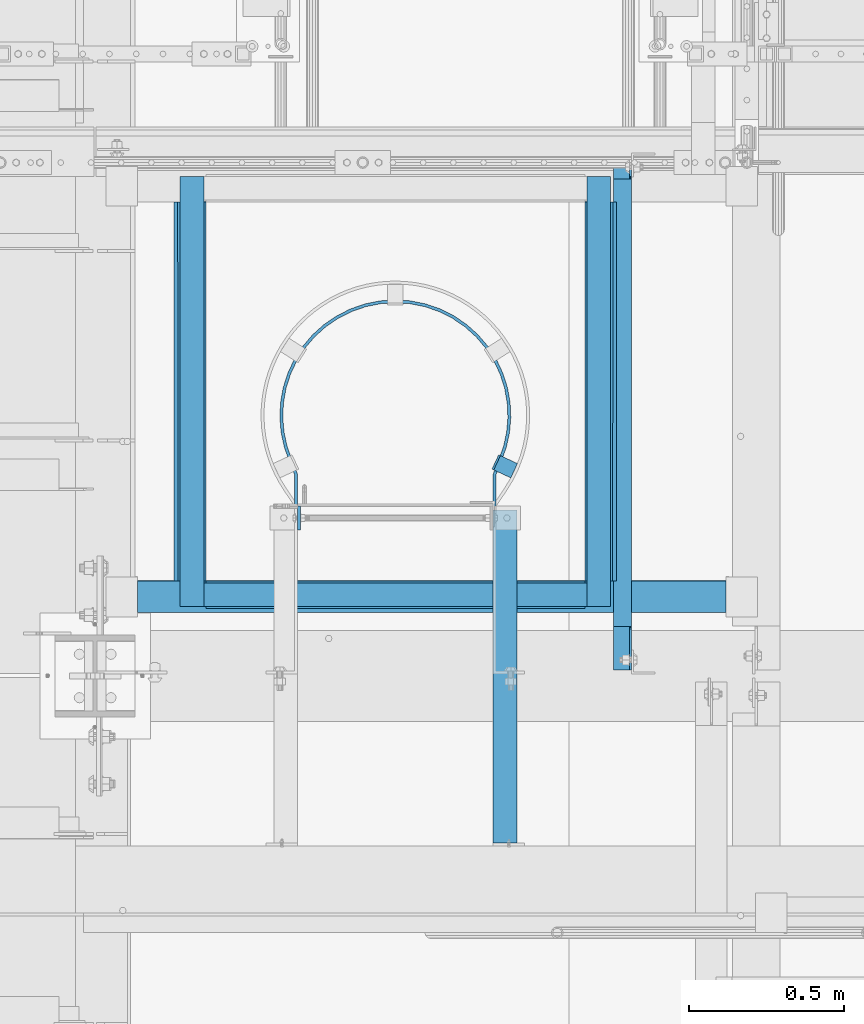
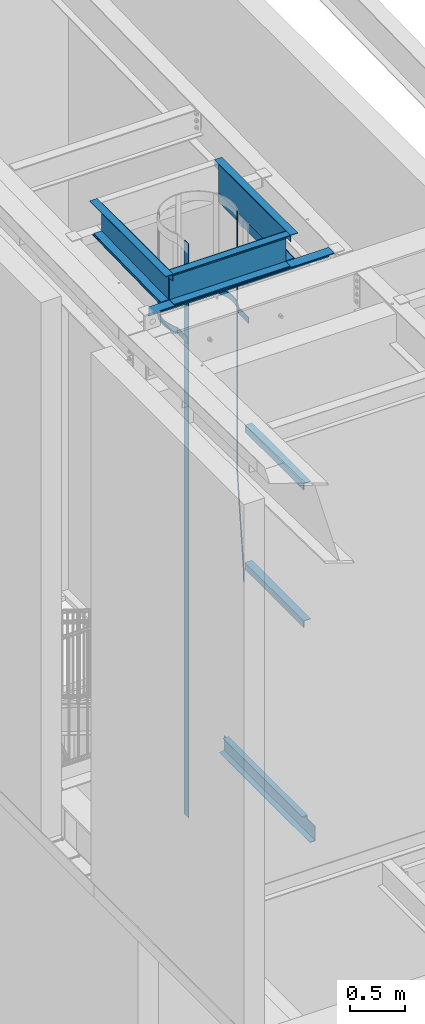
# One storey, part 1079 of 1763: 15 beams, 4 elements without a shape of their own.
"""IFC2X3 building model written with IfcOpenShell, lengths in millimetres."""

from ifc_helpers import new_model, si_unit, frame, origin_with_axes, place, context, subcontext, project, spatial, faceted_brep, material, type_object, element, aggregate, save


model = new_model("IFC2X3")

# Units and contexts
model_context = context("Model", 3, precision=1e-05, world=origin_with_axes())
body_context = subcontext(model_context, "Body", "Model", "MODEL_VIEW")
ifc_project = project(units=[si_unit("LENGTHUNIT", "METRE", prefix="MILLI"), si_unit("AREAUNIT", "SQUARE_METRE"), si_unit("VOLUMEUNIT", "CUBIC_METRE"), si_unit("MASSUNIT", "GRAM", prefix="KILO"), si_unit("TIMEUNIT", "SECOND"), si_unit("PLANEANGLEUNIT", "RADIAN"), si_unit("SOLIDANGLEUNIT", "STERADIAN"), si_unit("THERMODYNAMICTEMPERATUREUNIT", "DEGREE_CELSIUS"), si_unit("LUMINOUSINTENSITYUNIT", "LUMEN")], contexts=[model_context])

# Site, building, storey
site_placement = place(None, origin_with_axes())
site = spatial("IfcSite", under=ifc_project, at=site_placement, CompositionType="ELEMENT")
building_placement = place(site_placement, origin_with_axes())
building = spatial("IfcBuilding", under=site, at=building_placement, Name="Undefined", CompositionType="ELEMENT")
storey_placement = place(building_placement, origin_with_axes())
storey = spatial("IfcBuildingStorey", under=building, at=storey_placement, Name="Undefined", CompositionType="ELEMENT", Elevation=0.0)

# Assembly, beams
assembly_1_placement = place(storey_placement, origin_with_axes())
assembly_1 = element("IfcElementAssembly", 1, at=assembly_1_placement, inside=storey, Name="ANGLE", AssemblyPlace="NOTDEFINED", PredefinedType="RIGID_FRAME")
ifc_material = material(Name="STEEL/A36")
beam_type_1 = type_object("IfcBeamType", Name="L4X4X3/8", PredefinedType="NOTDEFINED")
beam_1_placement = place(assembly_1_placement, frame((-85749.8046875, 30328.926989345, 11245.4581872207), z_axis=(1.0, 0.0, 0.0), x_axis=(0.0, 0.999779834654609, 0.0209829029927513)))
beam_1 = element("IfcBeam", 2, at=beam_1_placement, type_object=beam_type_1, material=ifc_material, Name="ANGLE", ObjectType="L4X4X3/8", context=body_context, shape_type="Brep", body=[
    faceted_brep([(-3.63797880709171e-11, 50.8000000000011, -50.8000000000538), (-1.96450855582952e-10, 50.8000000000393, 50.7999999999374), (1219.28504414436, 50.8000000010161, 50.8000000000029), (1219.28504414436, 50.8000000010161, -50.8000000000029), (0.0, 41.2749999999996, 50.7999999999993), (1219.28504414434, 41.2750000010237, 50.8000000000029), (0.0, 41.2749999999996, -41.2750000000015), (1219.28504414434, 41.2750000010237, -41.2749999999942), (0.0, -50.7999999999993, -41.2750000000015), (1219.28504414426, -50.7999999989152, -41.2749999999942), (2.11002770811319e-10, -50.8000000000357, -50.799999999952), (1219.28504414426, -50.7999999989152, -50.8000000000029)], [[[0, 1, 2, 3]], [[1, 4, 5, 2]], [[4, 6, 7, 5]], [[6, 8, 9, 7]], [[8, 10, 11, 9]], [[10, 0, 3, 11]], [[5, 7, 9, 11, 3, 2]], [[10, 8, 6, 4, 1, 0]]]),
])
beam_2_placement = place(assembly_1_placement, frame((-87070.6046875, 31547.9435891844, 11271.0423265732), z_axis=(-1.0, 0.0, 0.0), x_axis=(0.0, -0.999779834654609, -0.0209829029927513)))
beam_2 = element("IfcBeam", 3, at=beam_2_placement, type_object=beam_type_1, material=ifc_material, Name="ANGLE", ObjectType="L4X4X3/8", context=body_context, shape_type="Brep", body=[
    faceted_brep([(-3.63797880709171e-11, 50.8000000000011, -50.8000000000538), (-1.96450855582952e-10, 50.8000000000393, 50.7999999999374), (1219.28504414436, 50.8000000010161, 50.8000000000029), (1219.28504414436, 50.8000000010161, -50.8000000000029), (0.0, 41.2749999999996, 50.7999999999993), (1219.28504414434, 41.2750000010237, 50.8000000000029), (0.0, 41.2749999999996, -41.2750000000015), (1219.28504414434, 41.2750000010237, -41.2749999999942), (0.0, -50.7999999999993, -41.2750000000015), (1219.28504414426, -50.7999999989152, -41.2749999999942), (2.11002770811319e-10, -50.8000000000357, -50.799999999952), (1219.28504414426, -50.7999999989152, -50.8000000000029)], [[[0, 1, 2, 3]], [[1, 4, 5, 2]], [[4, 6, 7, 5]], [[6, 8, 9, 7]], [[8, 10, 11, 9]], [[10, 0, 3, 11]], [[5, 7, 9, 11, 3, 2]], [[10, 8, 6, 4, 1, 0]]]),
])
beam_3_placement = place(assembly_1_placement, frame((-87238.9122736984, 30278.1707527682, 11244.3929395204), z_axis=(0.0, -0.999779834654609, -0.0209829029927513), x_axis=(1.0, 0.0, 0.0)))
beam_3 = element("IfcBeam", 4, at=beam_3_placement, type_object=beam_type_1, material=ifc_material, Name="ANGLE", ObjectType="L4X4X3/8", context=body_context, shape_type="Brep", body=[
    faceted_brep([(-3.63797880709171e-11, 50.8000000000011, -50.8000000000538), (-1.96450855582952e-10, 50.8000000000393, 50.7999999999374), (1891.39285714286, 50.8000000000102, 50.8000000001084), (1891.39285714286, 50.7999999999211, -50.8000000000138), (0.0, 41.2749999999996, 50.7999999999993), (1891.39285714286, 41.2750000000142, 50.8000000001011), (0.0, 41.2749999999996, -41.2750000000015), (1891.39285714286, 41.2749999999342, -41.2750000000087), (0.0, -50.7999999999993, -41.2750000000015), (1891.39285714286, -50.8000000000029, -41.275000000096), (2.11002770811319e-10, -50.8000000000357, -50.799999999952), (1891.39285714286, -50.800000000012, -50.8000000001048)], [[[0, 1, 2, 3]], [[1, 4, 5, 2]], [[4, 6, 7, 5]], [[6, 8, 9, 7]], [[8, 10, 11, 9]], [[10, 0, 3, 11]], [[5, 7, 9, 11, 3, 2]], [[10, 8, 6, 4, 1, 0]]]),
])
aggregate(assembly_1, [beam_1, beam_2, beam_3])

assembly_2_placement = place(storey_placement, origin_with_axes())
assembly_2 = element("IfcElementAssembly", 5, at=assembly_2_placement, inside=storey, Name="LADDER", AssemblyPlace="NOTDEFINED", PredefinedType="RIGID_FRAME")
beam_type_2 = type_object("IfcBeamType", Name="L3X3X1/4", PredefinedType="NOTDEFINED")
beam_4_placement = place(assembly_2_placement, frame((-86057.8122617073, 29486.2249999971, 9410.7), z_axis=(1.0, 0.0, 0.0), x_axis=(0.0, 1.0, 0.0)))
beam_4 = element("IfcBeam", 6, at=beam_4_placement, type_object=beam_type_2, material=ifc_material, Name="ANGLE", ObjectType="L3X3X1/4", context=body_context, shape_type="Brep", body=[
    faceted_brep([(0.0, 38.0999999999985, -38.1000000000004), (0.0, 38.0999999999985, 38.1000000000004), (1069.97500607761, 38.1000000000004, 38.1000000000058), (1069.97500607761, 38.1000000000004, -38.1000000000058), (0.0, 31.75, 38.1000000000058), (1069.97500607761, 31.75, 38.1000000000058), (0.0, 31.75, -31.75), (1069.97500607761, 31.75, -31.75), (0.0, -38.1000000000004, -31.75), (1069.97500607761, -38.1000000000004, -31.75), (0.0, -38.0999999999985, -38.1000000000004), (1069.97500607761, -38.1000000000004, -38.1000000000058)], [[[0, 1, 2, 3]], [[1, 4, 5, 2]], [[4, 6, 7, 5]], [[6, 8, 9, 7]], [[8, 10, 11, 9]], [[10, 0, 3, 11]], [[5, 7, 9, 11, 3, 2]], [[10, 8, 6, 4, 1, 0]]]),
])
beam_5_placement = place(assembly_2_placement, frame((-86057.8122617073, 29486.2249999971, 7886.70000005696), z_axis=(1.0, 0.0, 0.0), x_axis=(0.0, 1.0, 0.0)))
beam_5 = element("IfcBeam", 7, at=beam_5_placement, type_object=beam_type_2, material=ifc_material, Name="ANGLE", ObjectType="L3X3X1/4", context=body_context, shape_type="Brep", body=[
    faceted_brep([(0.0, 38.0999999999985, -38.1000000000004), (0.0, 38.0999999999985, 38.1000000000004), (1069.97500607761, 38.1000000000004, 38.1000000000058), (1069.97500607761, 38.1000000000004, -38.1000000000058), (0.0, 31.75, 38.1000000000058), (1069.97500607761, 31.75, 38.1000000000058), (0.0, 31.75, -31.75), (1069.97500607761, 31.75, -31.75), (0.0, -38.1000000000004, -31.75), (1069.97500607761, -38.1000000000004, -31.75), (0.0, -38.0999999999985, -38.1000000000004), (1069.97500607761, -38.1000000000004, -38.1000000000058)], [[[0, 1, 2, 3]], [[1, 4, 5, 2]], [[4, 6, 7, 5]], [[6, 8, 9, 7]], [[8, 10, 11, 9]], [[10, 0, 3, 11]], [[5, 7, 9, 11, 3, 2]], [[10, 8, 6, 4, 1, 0]]]),
])

assembly_3_placement = place(storey_placement, origin_with_axes())
assembly_3 = element("IfcElementAssembly", 8, at=assembly_3_placement, inside=storey, Name="BENT_PLATE", AssemblyPlace="NOTDEFINED", PredefinedType="RIGID_FRAME")
beam_6_placement = place(assembly_3_placement, frame((-85756.1294771174, 30245.8111638009, 11597.7774622409), z_axis=(1.0, 0.0, 0.0), x_axis=(0.0, 1.0, 0.0)))
beam_6 = element("IfcBeam", 9, at=beam_6_placement, type_object=beam_type_2, material=ifc_material, Name="ANGLE", ObjectType="L3X3X1/4", context=body_context, shape_type="Brep", body=[
    faceted_brep([(0.0, 38.0999999999985, -38.1000000000004), (0.0, 38.0999999999985, 38.1000000000004), (1383.50625000002, 38.1000000000004, 38.1000000000058), (1383.50625000002, 38.1000000000004, -38.1000000000058), (0.0, 31.75, 38.1000000000058), (1383.50625000002, 31.75, 38.1000000000058), (0.0, 31.75, -31.75), (1383.50625000002, 31.75, -31.75), (0.0, -38.1000000000004, -31.75), (1383.50625000002, -38.1000000000004, -31.75), (0.0, -38.0999999999985, -38.1000000000004), (1383.50625000002, -38.1000000000004, -38.1000000000058)], [[[0, 1, 2, 3]], [[1, 4, 5, 2]], [[4, 6, 7, 5]], [[6, 8, 9, 7]], [[8, 10, 11, 9]], [[10, 0, 3, 11]], [[5, 7, 9, 11, 3, 2]], [[10, 8, 6, 4, 1, 0]]]),
])
beam_7_placement = place(assembly_3_placement, frame((-87026.1872736991, 30283.9185396174, 11597.7774622409), z_axis=(0.0, -1.0, 0.0), x_axis=(1.0, 0.0, 0.0)))
beam_7 = element("IfcBeam", 10, at=beam_7_placement, type_object=beam_type_2, material=ifc_material, Name="ANGLE", ObjectType="L3X3X1/4", context=body_context, shape_type="Brep", body=[
    faceted_brep([(0.0, 38.0999999999985, -38.1000000000004), (0.0, 38.0999999999985, 38.1000000000004), (1231.90000000002, 38.1000000000004, 38.0999999999985), (1231.90000000002, 38.1000000000004, -38.0999999999985), (0.0, 31.75, 38.1000000000058), (1231.90000000002, 31.75, 38.0999999999985), (0.0, 31.75, -31.75), (1231.90000000002, 31.75, -31.75), (0.0, -38.1000000000004, -31.75), (1231.90000000002, -38.1000000000004, -31.75), (0.0, -38.0999999999985, -38.1000000000004), (1231.90000000002, -38.1000000000004, -38.0999999999985)], [[[0, 1, 2, 3]], [[1, 4, 5, 2]], [[4, 6, 7, 5]], [[6, 8, 9, 7]], [[8, 10, 11, 9]], [[10, 0, 3, 11]], [[5, 7, 9, 11, 3, 2]], [[10, 8, 6, 4, 1, 0]]]),
])
beam_8_placement = place(assembly_3_placement, frame((-87064.2798978826, 31629.317413801, 11597.7774622409), z_axis=(-1.0, 0.0, 0.0), x_axis=(0.0, -1.0, 0.0)))
beam_8 = element("IfcBeam", 11, at=beam_8_placement, type_object=beam_type_2, material=ifc_material, Name="ANGLE", ObjectType="L3X3X1/4", context=body_context, shape_type="Brep", body=[
    faceted_brep([(0.0, 38.0999999999985, -38.1000000000004), (0.0, 38.0999999999985, 38.1000000000004), (1383.50625000002, 38.1000000000004, 38.1000000000058), (1383.50625000002, 38.1000000000004, -38.1000000000058), (0.0, 31.75, 38.1000000000058), (1383.50625000002, 31.75, 38.1000000000058), (0.0, 31.75, -31.75), (1383.50625000002, 31.75, -31.75), (0.0, -38.1000000000004, -31.75), (1383.50625000002, -38.1000000000004, -31.75), (0.0, -38.0999999999985, -38.1000000000004), (1383.50625000002, -38.1000000000004, -38.1000000000058)], [[[0, 1, 2, 3]], [[1, 4, 5, 2]], [[4, 6, 7, 5]], [[6, 8, 9, 7]], [[8, 10, 11, 9]], [[10, 0, 3, 11]], [[5, 7, 9, 11, 3, 2]], [[10, 8, 6, 4, 1, 0]]]),
])

# Beam
beam_type_3 = type_object("IfcBeamType", PredefinedType="NOTDEFINED")
beam_9_placement = place(assembly_2_placement, frame((-86031.0966448988, 30684.2038212684, 7620.00000000017), z_axis=(0.422618261967727, 0.906307786930785, 0.0), x_axis=(0.0, 0.0, 1.0)))
beam_9 = element("IfcBeam", 12, at=beam_9_placement, type_object=beam_type_3, material=ifc_material, Name="PLATE", context=body_context, shape_type="Brep", body=[
    faceted_brep([(0.0, -3.17500000017753, -25.4000000001233), (0.0, -3.17499999987194, 25.4000000001051), (0.0, 3.17500000014843, 25.4000000001197), (0.0, 3.17499999984284, -25.4000000001088), (76.1999969380622, 3.17500000014843, 25.4000000001197), (76.1999969380695, 3.17499999984284, -25.4000000001088), (76.0331158036188, -3.17500000017753, -25.4000000001197), (76.0331158036115, -3.17499999987194, 25.4000000001051), (1225.55004882846, -57.2777259409777, 25.400000000287), (1225.55004882847, -57.2777259412833, -25.3999999999487), (1225.38316769402, -63.6277259413182, -25.3999999999633), (1225.38316769401, -63.6277259410126, 25.4000000002725), (4092.07739257812, -57.2777259409631, 25.4000000002798), (4092.07739257812, -57.2777259412833, -25.399999999956), (4092.07739257812, -63.6277259410126, 25.4000000002652), (4092.07739257812, -63.6277259413182, -25.3999999999705)], [[[0, 1, 2, 3]], [[3, 2, 4, 5]], [[1, 0, 6, 7]], [[5, 4, 8, 9]], [[7, 6, 10, 11]], [[9, 8, 12, 13]], [[8, 4, 2, 1, 7, 11, 14, 12]], [[11, 10, 15, 14]], [[10, 6, 0, 3, 5, 9, 13, 15]], [[14, 15, 13, 12]]]),
])

beam_type_4 = type_object("IfcBeamType", PredefinedType="NOTDEFINED")
beam_10_placement = place(assembly_2_placement, frame((-86091.1497736991, 30492.7, 10645.2774622366), z_axis=(0.0, 0.0, 1.0), x_axis=(0.0, 1.0, 0.0)))
beam_10 = element("IfcBeam", 13, at=beam_10_placement, type_object=beam_type_4, material=ifc_material, Name="PLATE", context=body_context, shape_type="Brep", body=[
    faceted_brep([(0.0, -4.76249999999709, -31.75), (0.0, -4.76250000000073, 31.75), (0.0, 4.76250000000073, 31.75), (0.0, 4.76249999999709, -31.75), (178.996850182604, 4.76249999999709, 31.75), (178.996850182604, 4.76249999999709, -31.75), (177.198920081068, -4.76249999999709, -31.75), (177.198920081068, -4.76249999999709, 31.75), (223.923672469686, -12.8248261728149, 31.75), (223.923672469686, -12.8248261728149, -31.75), (220.301876254001, -21.6358444885554, -31.75), (220.301876254001, -21.6358444885554, 31.75), (225.062862920662, -13.315718922473, 31.75), (225.062862920662, -13.315718922473, -31.75), (221.293479549164, -22.0631399137492, -31.75), (221.293479549164, -22.0631399137492, 31.75), (268.797622331076, -28.9179700700479, 31.75), (268.797622331076, -28.9179700700479, -31.75), (266.179279316701, -38.0760214380571, -31.75), (266.179279316701, -38.0760214380571, 31.75), (312.745907862791, -48.2099496661976, -31.75), (312.745907862791, -48.2099496661976, 31.75), (314.170107762209, -38.7920263469859, 31.75), (314.170241653486, -38.7920465962816, -31.75), (361.121282329259, -42.7913046950562, 31.75), (361.121282318767, -42.7913046948524, -31.75), (360.932367573077, -52.3144310837524, -31.75), (360.932367573077, -52.3144310837524, 31.75), (408.553266824139, -40.6172059538658, 31.75), (408.55326734237, -40.6172058958764, -31.75), (409.612565695392, -50.0831190583413, -31.75), (409.612565695392, -50.0831190583413, 31.75), (455.29255648837, -32.2529272571555, 31.75), (455.292556022912, -32.2529273724067, -31.75), (457.581833160064, -41.4987283214577, -31.75), (457.581833160064, -41.4987283214577, 31.75), (500.534787634006, -17.8424056936346, 31.75), (500.534787766108, -17.8424056417862, -31.75), (504.014650842557, -26.7089820932306, -31.75), (504.014650842557, -26.7089820932306, 31.75), (543.501358126799, 2.36636306563742, 31.75), (543.501358463509, 2.36636325190193, -31.75), (548.111923123197, -5.96840240281017, -31.75), (548.111923123197, -5.96840240281017, 31.75), (584.009198027747, 28.437626318133, 31.75), (584.009196713676, 28.4376253428782, -31.75), (589.685748261316, 20.7889399965643, -31.75), (589.685748261316, 20.7889399965643, 31.75), (620.696023637076, 59.6572758920083, 31.75), (620.696025797544, 59.6572779939015, -31.75), (627.338033980115, 52.8301737539878, -31.75), (627.338033980115, 52.8301737539878, 31.75), (652.912087062563, 95.4723277354788, 31.75), (652.91208579253, 95.4723261190084, -31.75), (660.401877781187, 89.5877155994822, -31.75), (660.401877781187, 89.5877155994822, 31.75), (680.086755434721, 135.248364146639, 31.75), (680.086754505715, 135.248362571074, -31.75), (688.291662534022, 130.410479847502, -31.75), (688.291662534022, 130.410479847502, 31.75), (701.738563283165, 178.280798617299, 31.75), (701.73856488548, 178.280802411682, -31.75), (710.513267771523, 174.575372037012, -31.75), (710.513267771523, 174.575372037012, 31.75), (717.484088221368, 223.807419031116, 31.75), (717.484087259192, 223.80741550494, -31.75), (726.673138341132, 221.300033361462, -31.75), (726.673138341132, 221.300033361462, 31.75), (727.044327443258, 271.021749271633, 31.75), (727.044327941214, 271.021752988236, -31.75), (736.484969431742, 269.756876216648, -31.75), (736.484969431742, 269.756876216648, 31.75), (730.250012207038, 319.087498404828, 31.75), (730.250012207031, 319.087495313172, -31.75), (739.775012207032, 319.087489388141, -31.75), (739.775012207032, 319.087489388141, 31.75), (727.044328675405, 367.153259842584, 31.75), (727.044328513592, 367.153261050305, -31.75), (736.484968199595, 368.418151290229, -31.75), (736.484968199595, 368.418151290229, 31.75), (717.484085293047, 414.367594752388, 31.75), (717.484085562104, 414.367593766336, -31.75), (726.673141269457, 416.87495895855, -31.75), (726.673141269457, 416.87495895855, 31.75), (701.738568815384, 459.894191333835, 31.75), (701.738567727607, 459.894193909757, -31.75), (710.513262239299, 463.599644115384, -31.75), (710.513262239299, 463.599644115384, 31.75), (680.086748702986, 502.926650321984, 31.75), (680.086750557224, 502.926647177228, -31.75), (688.29166926576, 507.764511787405, -31.75), (688.29166926576, 507.764511787405, 31.75), (652.912093282088, 542.702644512043, 31.75), (652.912090596754, 542.702647929866, -31.75), (660.401871561658, 548.58727248013, -31.75), (660.401871561658, 548.58727248013, 31.75), (620.696019913037, 578.51772696813, 31.75), (620.696024247423, 578.517722751247, -31.75), (627.338037704154, 585.344821859995, -31.75), (627.338037704154, 585.344821859995, 31.75), (584.009197168081, 609.737364020199, 31.75), (584.009193942664, 609.737366413974, -31.75), (589.685749120978, 617.386049065753, -31.75), (589.685749120978, 617.386049065753, 31.75), (543.501362367231, 635.808628103681, 31.75), (543.501361835584, 635.808628397775, -31.75), (548.111918882772, 644.143398263506, -31.75), (548.111918882772, 644.143398263506, 31.75), (500.534784456919, 656.017396640862, 31.75), (500.534786494096, 656.017395841336, -31.75), (504.014654019651, 664.883970546623, -31.75), (504.014654019651, 664.883970546623, 31.75), (455.292552670799, 670.427942698254, 31.75), (455.292552716117, 670.427942687034, -31.75), (457.581836977639, 679.673741872059, -31.75), (457.581836977639, 679.673741872059, 31.75), (408.553277115458, 678.792188780484, 31.75), (408.553273513717, 678.792189183543, -31.75), (409.61255540407, 688.258104188266, -31.75), (409.61255540407, 688.258104188266, 31.75), (361.121277097478, 680.966280940163, 31.75), (361.12128097919, 680.966281017158, -31.75), (360.932372804862, 690.489407536414, -31.75), (360.932372804862, 690.489407536414, 31.75), (314.170242988643, 676.96702314711, 31.75), (314.170241809003, 676.967022968674, -31.75), (312.745772636365, 686.384905563842, -31.75), (312.745772636365, 686.384905563842, 31.75), (268.136629496974, 666.902248529776, 31.75), (268.136630694469, 666.902248874627, -31.75), (265.500760639741, 676.055271001474, -31.75), (265.500760639741, 676.055271001474, 31.75), (225.062605304862, 651.49063320244, 31.75), (225.062857896504, 651.490742038819, -31.75), (221.29373196304, 660.238273954848, -31.75), (221.29373196304, 660.238273954848, 31.75), (223.92367006966, 650.999851168279, 31.75), (223.92367006966, 650.999851168279, -31.75), (220.301873029875, 659.81086903195, -31.75), (220.301873029875, 659.81086903195, 31.75), (178.996852032531, 633.412487792972, 31.75), (178.996852032531, 633.412487792972, -31.75), (177.198918231141, 642.937487792966, -31.75), (177.198918231141, 642.937487792966, 31.75), (0.0, 633.412487792972, 31.75), (0.0, 633.412487792972, -31.75), (0.0, 642.937487792966, 31.75), (0.0, 642.937487792966, -31.75)], [[[0, 1, 2, 3]], [[3, 2, 4, 5]], [[1, 0, 6, 7]], [[5, 4, 8, 9]], [[7, 6, 10, 11]], [[9, 8, 12, 13]], [[11, 10, 14, 15]], [[13, 12, 16, 17]], [[15, 14, 18, 19]], [[18, 20, 21, 19]], [[16, 22, 23, 17]], [[23, 22, 24, 25]], [[21, 20, 26, 27]], [[25, 24, 28, 29]], [[27, 26, 30, 31]], [[29, 28, 32, 33]], [[31, 30, 34, 35]], [[33, 32, 36, 37]], [[35, 34, 38, 39]], [[37, 36, 40, 41]], [[39, 38, 42, 43]], [[41, 40, 44, 45]], [[43, 42, 46, 47]], [[45, 44, 48, 49]], [[47, 46, 50, 51]], [[49, 48, 52, 53]], [[51, 50, 54, 55]], [[53, 52, 56, 57]], [[55, 54, 58, 59]], [[57, 56, 60, 61]], [[59, 58, 62, 63]], [[61, 60, 64, 65]], [[63, 62, 66, 67]], [[65, 64, 68, 69]], [[67, 66, 70, 71]], [[69, 68, 72, 73]], [[71, 70, 74, 75]], [[73, 72, 76, 77]], [[75, 74, 78, 79]], [[77, 76, 80, 81]], [[79, 78, 82, 83]], [[81, 80, 84, 85]], [[83, 82, 86, 87]], [[85, 84, 88, 89]], [[87, 86, 90, 91]], [[89, 88, 92, 93]], [[91, 90, 94, 95]], [[93, 92, 96, 97]], [[95, 94, 98, 99]], [[97, 96, 100, 101]], [[99, 98, 102, 103]], [[101, 100, 104, 105]], [[103, 102, 106, 107]], [[105, 104, 108, 109]], [[107, 106, 110, 111]], [[109, 108, 112, 113]], [[111, 110, 114, 115]], [[113, 112, 116, 117]], [[115, 114, 118, 119]], [[117, 116, 120, 121]], [[119, 118, 122, 123]], [[121, 120, 124, 125]], [[123, 122, 126, 127]], [[125, 124, 128, 129]], [[127, 126, 130, 131]], [[129, 128, 132, 133]], [[131, 130, 134, 135]], [[133, 132, 136, 137]], [[135, 134, 138, 139]], [[137, 136, 140, 141]], [[139, 138, 142, 143]], [[141, 140, 144, 145]], [[140, 136, 132, 128, 124, 120, 116, 112, 108, 104, 100, 96, 92, 88, 84, 80, 76, 72, 68, 64, 60, 56, 52, 48, 44, 40, 36, 32, 28, 24, 22, 16, 12, 8, 4, 2, 1, 7, 11, 15, 19, 21, 27, 31, 35, 39, 43, 47, 51, 55, 59, 63, 67, 71, 75, 79, 83, 87, 91, 95, 99, 103, 107, 111, 115, 119, 123, 127, 131, 135, 139, 143, 146, 144]], [[143, 142, 147, 146]], [[142, 138, 134, 130, 126, 122, 118, 114, 110, 106, 102, 98, 94, 90, 86, 82, 78, 74, 70, 66, 62, 58, 54, 50, 46, 42, 38, 34, 30, 26, 20, 18, 14, 10, 6, 0, 3, 5, 9, 13, 17, 23, 25, 29, 33, 37, 41, 45, 49, 53, 57, 61, 65, 69, 73, 77, 81, 85, 89, 93, 97, 101, 105, 109, 113, 117, 121, 125, 129, 133, 137, 141, 145, 147]], [[146, 147, 145, 144]]]),
])

beam_type_5 = type_object("IfcBeamType", PredefinedType="NOTDEFINED")
beam_11_placement = place(assembly_2_placement, frame((-86719.7997736991, 30530.8, 11712.0774622366), z_axis=(0.0, -1.0, 0.0), x_axis=(0.0, 0.0, -1.0)))
beam_11 = element("IfcBeam", 14, at=beam_11_placement, type_object=beam_type_5, material=ifc_material, Name="LADDER", context=body_context, shape_type="Brep", body=[
    faceted_brep([(0.0, 4.76249999999709, -38.1000000000004), (0.0, 4.76249999999709, 38.1000000000004), (6365.37746223656, 4.76249999999709, 38.0999999999985), (6365.37746223656, 4.76249999999709, -38.0999999999985), (0.0, -4.76249999999709, 38.1000000000004), (6365.37746223656, -4.76249999999709, 38.0999999999985), (0.0, -4.76249999999709, -38.1000000000004), (6365.37746223656, -4.76249999999709, -38.0999999999985)], [[[0, 1, 2, 3]], [[1, 4, 5, 2]], [[4, 6, 7, 5]], [[6, 0, 3, 7]], [[5, 7, 3, 2]], [[6, 4, 1, 0]]]),
])

aggregate(assembly_2, [beam_4, beam_5, beam_9, beam_10, beam_11])

# Assembly, beam
assembly_4_placement = place(storey_placement, origin_with_axes())
assembly_4 = element("IfcElementAssembly", 15, at=assembly_4_placement, inside=storey, Name="CHANNEL", AssemblyPlace="NOTDEFINED", PredefinedType="RIGID_FRAME")
beam_type_6 = type_object("IfcBeamType", Name="C8X11.5", PredefinedType="NOTDEFINED")
beam_12_placement = place(assembly_4_placement, frame((-85679.9220001979, 30022.8000000956, 5092.70000006338), z_axis=(0.0, 0.0, -1.0), x_axis=(0.0, 1.0, 0.0)))
beam_12 = element("IfcBeam", 16, at=beam_12_placement, type_object=beam_type_6, material=ifc_material, Name="CHANNEL", ObjectType="C8X11.5", context=body_context, shape_type="Brep", body=[
    faceted_brep([(1598.6125000386, 22.2250000000058, -88.3723149999996), (1598.6125000386, -28.5749999999971, -96.8355949999996), (1598.6125000386, -28.5749999999971, -101.6), (1598.6125000386, 28.5749999999971, -101.6), (1598.6125000386, 28.5749999999971, -82.5499998092664), (1598.6125000386, 22.2250000000058, -82.5499998092664), (1599.57922996119, 28.5749999999971, -77.6899202912209), (1599.57922996119, 22.2250000000058, -77.6899202912209), (1602.33224386167, 28.5749999999971, -73.5697438230673), (1602.33224386167, 22.2250000000058, -73.5697438230673), (1606.45242032982, 28.5749999999971, -70.8167299225888), (1606.45242032982, 22.2250000000058, -70.8167299225888), (1611.31249984787, 28.5749999999971, -69.8500000000013), (1611.31249984787, 22.2250000000058, -69.8500000000013), (1668.4625000386, 22.2250000000058, -69.8500000000013), (1668.4625000386, 28.5749999999971, -69.8500000000013), (19.8437499043794, -28.5749999999971, 101.6), (19.8437499043794, -28.5749999999971, 96.8355949999996), (1668.4625000386, -28.5749999999971, 96.8355949999996), (1668.4625000386, -28.5749999999971, 101.6), (19.8437499043794, 28.5749999999971, 101.6), (1668.4625000386, 28.5749999999971, 101.6), (159.54374990438, 22.2250000000058, -76.1999998092651), (159.54374990438, 28.5749999999971, -76.1999998092651), (159.54374990438, 28.5749999999971, -101.6), (159.54374990438, -28.5749999999971, -101.6), (159.54374990438, -28.5749999999971, -96.8355949999996), (159.54374990438, 22.2250000000058, -88.3723149999996), (158.577019981793, 22.2250000000058, -71.3399202912196), (158.577019981793, 28.5749999999971, -71.3399202912196), (155.824006081315, 22.2250000000058, -67.219743823066), (155.824006081315, 28.5749999999971, -67.219743823066), (151.703829613161, 22.2250000000058, -64.4667299225875), (151.703829613161, 28.5749999999971, -64.4667299225875), (146.843750095115, 22.2250000000058, -63.5), (146.843750095115, 28.5749999999971, -63.5), (19.8437499043794, 22.2250000000058, -63.5), (19.8437499043794, 28.5749999999971, -63.5), (19.8437499043794, 22.2250000000058, 88.3723149999996), (1668.4625000386, 22.2250000000058, 88.3723149999996)], [[[0, 1, 2, 3, 4, 5]], [[5, 4, 6, 7]], [[7, 6, 8, 9]], [[9, 8, 10, 11]], [[11, 10, 12, 13]], [[14, 13, 12, 15]], [[16, 17, 18, 19]], [[20, 16, 19, 21]], [[22, 23, 24, 25, 26, 27]], [[28, 29, 23, 22]], [[30, 31, 29, 28]], [[32, 33, 31, 30]], [[34, 35, 33, 32]], [[36, 37, 35, 34]], [[38, 17, 16, 20, 37, 36]], [[17, 38, 39, 18]], [[21, 19, 18, 39, 14, 15]], [[10, 8, 6, 4, 3, 24, 23, 29, 31, 33, 35, 37, 20, 21, 15, 12]], [[25, 24, 3, 2]], [[26, 25, 2, 1]], [[27, 26, 1, 0]], [[39, 38, 36, 34, 32, 30, 28, 22, 27, 0, 5, 7, 9, 11, 13, 14]]]),
])
aggregate(assembly_4, [beam_12])

# Beam
beam_type_7 = type_object("IfcBeamType", PredefinedType="NOTDEFINED")
beam_13_placement = place(assembly_3_placement, frame((-87109.4339840008, 30941.6285389193, 11312.4350763512), z_axis=(-0.00118130229203962, 0.999785629058708, 0.0206712470010534), x_axis=(0.999999151583596, 0.00116970199953315, 0.000573261999753955)))
beam_13 = element("IfcBeam", 17, at=beam_13_placement, type_object=beam_type_7, material=ifc_material, Name="BENT_PLATE", context=body_context, shape_type="Brep", body=[
    faceted_brep([(-0.00747467353357933, -3.17499999924075, -613.56849995369), (-0.00747390218020882, 3.17500000076143, -613.56849995369), (88.8766994313773, 3.17498920430808, -613.569582710832), (82.5303421693825, -3.17501002482277, -613.569505401647), (89.0799016641831, -336.081675053432, -606.546791828983), (82.7298983673682, -336.085314496007, -606.546714474385), (90.5049925148487, -310.805315409409, 612.044638022635), (84.1549892183102, -310.808955293111, 612.044715388292), (83.9707368617674, -3.17501019949123, 605.684177896113), (0.00737785833189264, -3.17500000075233, 605.684205566675), (0.00737703032791615, 3.17499999924803, 605.552915069937), (90.3169391094125, 3.17498902965781, 605.552885307956)], [[[0, 1, 2, 3]], [[3, 2, 4, 5]], [[5, 4, 6, 7]], [[3, 5, 7, 8]], [[0, 3, 8, 9]], [[1, 0, 9, 10]], [[2, 1, 10, 11]], [[4, 2, 11, 6]], [[10, 9, 8, 7, 6, 11]]]),
])

beam_14_placement = place(assembly_3_placement, frame((-85710.9765317091, 30940.8352092573, 11312.4186739526), z_axis=(0.00118097034269885, 0.999785629450702, 0.0206712470091315), x_axis=(-0.999999151972455, 0.00116936999995902, 0.000573260999990654)))
beam_14 = element("IfcBeam", 18, at=beam_14_placement, type_object=beam_type_7, material=ifc_material, Name="BENT_PLATE", context=body_context, shape_type="Brep", body=[
    faceted_brep([(-0.00726085848873481, -3.17500000130531, -612.774999956757), (-0.00726159260375425, 3.17499999869506, -612.774999956764), (82.5303420063719, 3.17500954032766, -612.775978006077), (88.8766992311721, -3.17498972601061, -612.776053208756), (82.7298978265317, 336.085313731041, -605.75318707529), (89.0799011233466, 336.081674251236, -605.75326232204), (84.1540883402486, 310.817647793139, 612.414102845538), (90.5040829565987, 310.814161873734, 612.406603043379), (90.4927557634655, 291.050498426159, 612.429723972498), (90.3165344773442, -3.17498955863084, 606.346415290682), (0.00718541555397678, -3.17499999870597, 606.346415074844), (0.00718623721331824, 3.17500000129439, 606.477705570422), (83.9703322233545, 3.1750097077238, 606.477705771096), (84.1429560185061, 291.393995565732, 612.43682600552)], [[[0, 1, 2, 3]], [[3, 2, 4, 5]], [[4, 6, 7, 5]], [[3, 5, 7, 8, 9]], [[0, 3, 9, 10]], [[1, 0, 10, 11]], [[2, 1, 11, 12]], [[6, 4, 2, 12, 13]], [[7, 6, 13, 8]], [[12, 11, 10, 9, 8, 13]]]),
])

beam_15_placement = place(assembly_3_placement, frame((-86410.2372736991, 30239.4253008968, 11297.9659144976), z_axis=(1.0, 0.0, 0.0), x_axis=(0.0, 0.999786493786436, 0.0206631759955948)))
beam_15 = element("IfcBeam", 19, at=beam_15_placement, type_object=beam_type_7, material=ifc_material, Name="BENT_PLATE", context=body_context, shape_type="Brep", body=[
    faceted_brep([(-1.94995664060116e-09, -3.17499999999927, -609.600000000006), (-1.94995664060116e-09, -3.17499999999927, 609.600000000006), (1.96087057702243e-09, 3.17500000000291, 609.600000000006), (1.96087057702243e-09, 3.17500000000291, -609.600000000006), (82.6764952535341, 3.17499994924037, 609.600000000006), (82.6764952535341, 3.17499994924037, -609.600000000006), (88.8966121194717, -3.17500005457987, -609.600000000006), (88.8966121194717, -3.17500005457987, 609.600000000006), (89.5579294749441, 336.132769524693, 609.600000000006), (89.5579294749441, 336.132769524693, -609.600000000006), (95.9065737104902, 336.001558357122, 609.600000000006), (95.9065737104902, 336.001558357122, -609.600000000006)], [[[0, 1, 2, 3]], [[3, 2, 4, 5]], [[1, 0, 6, 7]], [[5, 4, 8, 9]], [[4, 2, 1, 7, 10, 8]], [[7, 6, 11, 10]], [[6, 0, 3, 5, 9, 11]], [[10, 11, 9, 8]]]),
])

aggregate(assembly_3, [beam_6, beam_7, beam_8, beam_13, beam_14, beam_15])

save(model, "model.ifc")
